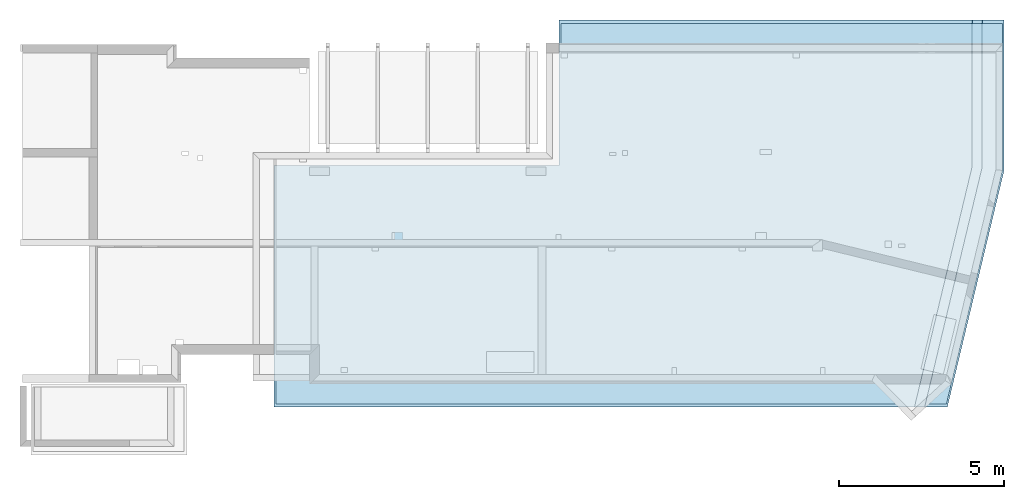
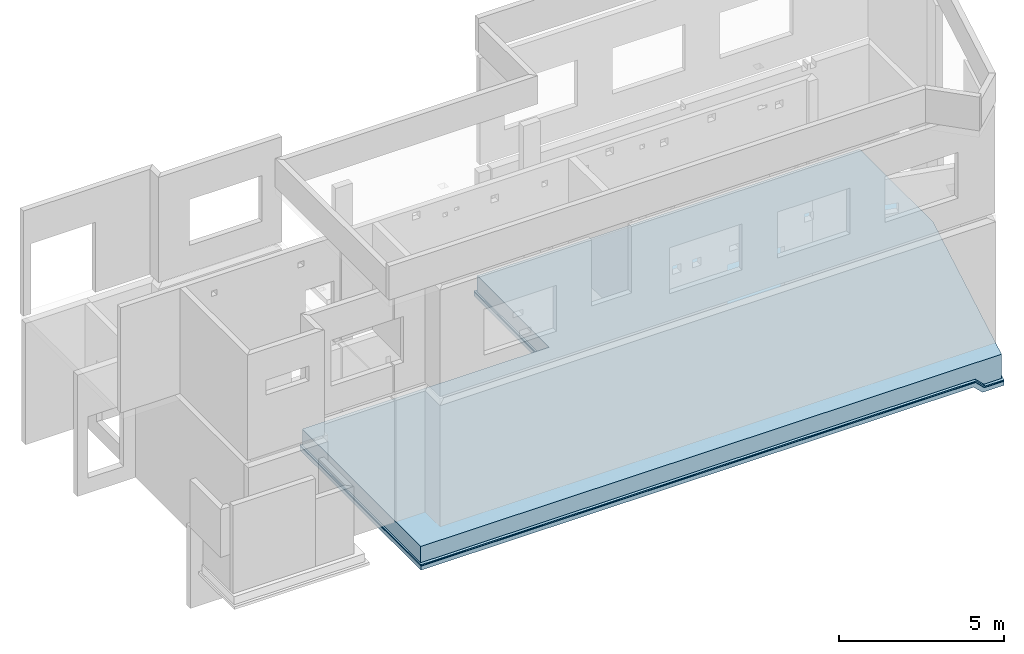
# One storey, part 7 of 7: 3 slabs.
"""IFC2X3 building model written with IfcOpenShell, lengths in millimetres."""

from ifc_helpers import new_model, entity, si_unit, converted_unit, derived_unit, money_unit, direction, frame, origin_with_axes, place, context, subcontext, project, spatial, faceted_brep, material, type_object, element, save


model = new_model("IFC2X3")

# Units and contexts
model_context = context("Model", 3, precision=1e-05, world=origin_with_axes(), true_north=direction((0.0, 1.0)))
body_context = subcontext(model_context, "Body", "Model", "MODEL_VIEW", scale=1.0)
ifc_project = project(units=[si_unit("LENGTHUNIT", "METRE", prefix="MILLI"), si_unit("AREAUNIT", "SQUARE_METRE"), si_unit("VOLUMEUNIT", "CUBIC_METRE"), si_unit("ABSORBEDDOSEUNIT", "GRAY"), si_unit("AMOUNTOFSUBSTANCEUNIT", "MOLE"), si_unit("DOSEEQUIVALENTUNIT", "SIEVERT"), si_unit("ELECTRICCAPACITANCEUNIT", "FARAD"), si_unit("ELECTRICCHARGEUNIT", "COULOMB"), si_unit("ELECTRICCONDUCTANCEUNIT", "SIEMENS"), si_unit("ELECTRICCURRENTUNIT", "AMPERE"), si_unit("ELECTRICRESISTANCEUNIT", "OHM"), si_unit("ELECTRICVOLTAGEUNIT", "VOLT"), si_unit("ENERGYUNIT", "JOULE"), si_unit("FORCEUNIT", "NEWTON"), si_unit("FREQUENCYUNIT", "HERTZ"), si_unit("ILLUMINANCEUNIT", "LUX"), si_unit("INDUCTANCEUNIT", "HENRY"), si_unit("LUMINOUSFLUXUNIT", "LUMEN"), si_unit("LUMINOUSINTENSITYUNIT", "CANDELA"), si_unit("MAGNETICFLUXDENSITYUNIT", "TESLA"), si_unit("MAGNETICFLUXUNIT", "WEBER"), si_unit("MASSUNIT", "GRAM"), converted_unit("PLANEANGLEUNIT", "degree", entity("IfcReal", 0.0174532925199433), si_unit("PLANEANGLEUNIT", "RADIAN"), dimensions=[0, 0, 0, 0, 0, 0, 0]), si_unit("POWERUNIT", "WATT"), si_unit("PRESSUREUNIT", "PASCAL"), si_unit("RADIOACTIVITYUNIT", "BECQUEREL"), si_unit("SOLIDANGLEUNIT", "STERADIAN"), si_unit("THERMODYNAMICTEMPERATUREUNIT", "KELVIN"), si_unit("TIMEUNIT", "SECOND"), derived_unit("ACCELERATIONUNIT", [(si_unit("LENGTHUNIT", "METRE", prefix="MILLI"), 1), (si_unit("TIMEUNIT", "SECOND"), -2)]), derived_unit("ANGULARVELOCITYUNIT", [(converted_unit("PLANEANGLEUNIT", "degree", entity("IfcReal", 0.0174532925199433), si_unit("PLANEANGLEUNIT", "RADIAN"), dimensions=[0, 0, 0, 0, 0, 0, 0]), 1), (si_unit("TIMEUNIT", "SECOND"), -1)]), derived_unit("CURVATUREUNIT", [(converted_unit("PLANEANGLEUNIT", "degree", entity("IfcReal", 0.0174532925199433), si_unit("PLANEANGLEUNIT", "RADIAN"), dimensions=[0, 0, 0, 0, 0, 0, 0]), 1), (si_unit("LENGTHUNIT", "METRE", prefix="MILLI"), -1)]), derived_unit("DYNAMICVISCOSITYUNIT", [(si_unit("PRESSUREUNIT", "PASCAL"), 1), (si_unit("TIMEUNIT", "SECOND"), 1)]), derived_unit("HEATFLUXDENSITYUNIT", [(si_unit("POWERUNIT", "WATT"), 1), (si_unit("LENGTHUNIT", "METRE", prefix="MILLI"), -2)]), derived_unit("HEATINGVALUEUNIT", [(si_unit("ENERGYUNIT", "JOULE"), 1), (si_unit("MASSUNIT", "GRAM"), -1)]), derived_unit("INTEGERCOUNTRATEUNIT", [(si_unit("TIMEUNIT", "SECOND"), -1)]), derived_unit("IONCONCENTRATIONUNIT", [(si_unit("MASSUNIT", "GRAM"), 1), (si_unit("VOLUMEUNIT", "CUBIC_METRE"), -1)]), derived_unit("ISOTHERMALMOISTURECAPACITYUNIT", [(si_unit("VOLUMEUNIT", "CUBIC_METRE"), 1), (si_unit("MASSUNIT", "GRAM"), -1)]), derived_unit("KINEMATICVISCOSITYUNIT", [(si_unit("AREAUNIT", "SQUARE_METRE"), 1), (si_unit("TIMEUNIT", "SECOND"), -1)]), derived_unit("LINEARFORCEUNIT", [(si_unit("FORCEUNIT", "NEWTON"), 1), (si_unit("LENGTHUNIT", "METRE", prefix="MILLI"), -1)]), derived_unit("LINEARMOMENTUNIT", [(si_unit("FORCEUNIT", "NEWTON"), 1), (si_unit("LENGTHUNIT", "METRE", prefix="MILLI"), -1)]), derived_unit("LINEARSTIFFNESSUNIT", [(si_unit("FORCEUNIT", "NEWTON"), 1), (si_unit("LENGTHUNIT", "METRE", prefix="MILLI"), -1)]), derived_unit("LINEARVELOCITYUNIT", [(si_unit("LENGTHUNIT", "METRE", prefix="MILLI"), 1), (si_unit("TIMEUNIT", "SECOND"), -1)]), derived_unit("LUMINOUSINTENSITYDISTRIBUTIONUNIT", [(si_unit("LUMINOUSINTENSITYUNIT", "CANDELA"), 1), (si_unit("LUMINOUSFLUXUNIT", "LUMEN"), -1)]), derived_unit("MASSDENSITYUNIT", [(si_unit("MASSUNIT", "GRAM"), 1), (si_unit("VOLUMEUNIT", "CUBIC_METRE"), -1)]), derived_unit("MASSFLOWRATEUNIT", [(si_unit("MASSUNIT", "GRAM"), 1), (si_unit("TIMEUNIT", "SECOND"), -1)]), derived_unit("MASSPERLENGTHUNIT", [(si_unit("MASSUNIT", "GRAM"), 1), (si_unit("LENGTHUNIT", "METRE", prefix="MILLI"), -1)]), derived_unit("MODULUSOFELASTICITYUNIT", [(si_unit("FORCEUNIT", "NEWTON"), 1), (si_unit("AREAUNIT", "SQUARE_METRE"), -1)]), derived_unit("MODULUSOFLINEARSUBGRADEREACTIONUNIT", [(si_unit("FORCEUNIT", "NEWTON"), 1), (si_unit("LENGTHUNIT", "METRE", prefix="MILLI"), -2)]), derived_unit("MODULUSOFROTATIONALSUBGRADEREACTIONUNIT", [(si_unit("FORCEUNIT", "NEWTON"), 1), (si_unit("LENGTHUNIT", "METRE", prefix="MILLI"), 1)]), derived_unit("MODULUSOFSUBGRADEREACTIONUNIT", [(si_unit("FORCEUNIT", "NEWTON"), 1), (si_unit("VOLUMEUNIT", "CUBIC_METRE"), -1)]), derived_unit("MOISTUREDIFFUSIVITYUNIT", [(si_unit("VOLUMEUNIT", "CUBIC_METRE"), 1), (si_unit("TIMEUNIT", "SECOND"), -1)]), derived_unit("MOLECULARWEIGHTUNIT", [(si_unit("MASSUNIT", "GRAM"), 1), (si_unit("AMOUNTOFSUBSTANCEUNIT", "MOLE"), -1)]), derived_unit("PLANARFORCEUNIT", [(si_unit("FORCEUNIT", "NEWTON"), 1), (si_unit("LENGTHUNIT", "METRE", prefix="MILLI"), -2)]), derived_unit("ROTATIONALFREQUENCYUNIT", [(si_unit("TIMEUNIT", "SECOND"), -1)]), derived_unit("ROTATIONALMASSUNIT", [(si_unit("MASSUNIT", "GRAM"), 1), (si_unit("LENGTHUNIT", "METRE", prefix="MILLI"), 2)]), derived_unit("ROTATIONALSTIFFNESSUNIT", [(si_unit("FORCEUNIT", "NEWTON"), 1), (si_unit("LENGTHUNIT", "METRE", prefix="MILLI"), 1), (converted_unit("PLANEANGLEUNIT", "degree", entity("IfcReal", 0.0174532925199433), si_unit("PLANEANGLEUNIT", "RADIAN"), dimensions=[0, 0, 0, 0, 0, 0, 0]), -1)]), derived_unit("SECTIONAREAINTEGRALUNIT", [(si_unit("LENGTHUNIT", "METRE", prefix="MILLI"), 5)]), derived_unit("SECTIONMODULUSUNIT", [(si_unit("LENGTHUNIT", "METRE", prefix="MILLI"), 3)]), derived_unit("SHEARMODULUSUNIT", [(si_unit("FORCEUNIT", "NEWTON"), 1), (si_unit("AREAUNIT", "SQUARE_METRE"), -1)]), derived_unit("SOUNDPOWERUNIT", [(si_unit("ENERGYUNIT", "JOULE"), 1), (si_unit("TIMEUNIT", "SECOND"), -1)]), derived_unit("SPECIFICHEATCAPACITYUNIT", [(si_unit("FORCEUNIT", "NEWTON"), 1), (si_unit("MASSUNIT", "GRAM"), -1), (si_unit("THERMODYNAMICTEMPERATUREUNIT", "KELVIN"), -1)]), derived_unit("TEMPERATUREGRADIENTUNIT", [(si_unit("THERMODYNAMICTEMPERATUREUNIT", "KELVIN"), 1), (si_unit("LENGTHUNIT", "METRE", prefix="MILLI"), -1)]), derived_unit("THERMALADMITTANCEUNIT", [(si_unit("POWERUNIT", "WATT"), 1), (si_unit("AREAUNIT", "SQUARE_METRE"), -1), (si_unit("THERMODYNAMICTEMPERATUREUNIT", "KELVIN"), -1)]), derived_unit("THERMALCONDUCTANCEUNIT", [(si_unit("POWERUNIT", "WATT"), 1), (si_unit("LENGTHUNIT", "METRE", prefix="MILLI"), -1), (si_unit("THERMODYNAMICTEMPERATUREUNIT", "KELVIN"), -1)]), derived_unit("THERMALEXPANSIONCOEFFICIENTUNIT", [(si_unit("THERMODYNAMICTEMPERATUREUNIT", "KELVIN"), -1)]), derived_unit("THERMALRESISTANCEUNIT", [(si_unit("AREAUNIT", "SQUARE_METRE"), 1), (si_unit("POWERUNIT", "WATT"), -1)]), derived_unit("THERMALTRANSMITTANCEUNIT", [(si_unit("POWERUNIT", "WATT"), 1), (si_unit("AREAUNIT", "SQUARE_METRE"), -1), (si_unit("THERMODYNAMICTEMPERATUREUNIT", "KELVIN"), -1)]), derived_unit("TORQUEUNIT", [(si_unit("FORCEUNIT", "NEWTON"), 1), (si_unit("LENGTHUNIT", "METRE", prefix="MILLI"), 1)]), derived_unit("VAPORPERMEABILITYUNIT", [(si_unit("MASSUNIT", "GRAM"), 1), (si_unit("TIMEUNIT", "SECOND"), -1)]), derived_unit("VOLUMETRICFLOWRATEUNIT", [(si_unit("VOLUMEUNIT", "CUBIC_METRE"), 1), (si_unit("TIMEUNIT", "SECOND"), -1)]), derived_unit("WARPINGCONSTANTUNIT", [(si_unit("LENGTHUNIT", "METRE", prefix="MILLI"), 6)]), derived_unit("WARPINGMOMENTUNIT", [(si_unit("FORCEUNIT", "NEWTON"), 1), (si_unit("LENGTHUNIT", "METRE", prefix="MILLI"), 2)]), money_unit("USD")], contexts=[model_context])

# Site, building, storey
site_placement = place(None, origin_with_axes())
site = spatial("IfcSite", under=ifc_project, at=site_placement, CompositionType="ELEMENT")
building_placement = place(site_placement, origin_with_axes())
building = spatial("IfcBuilding", under=site, at=building_placement, Name="1", CompositionType="ELEMENT")
storey_placement = place(building_placement, frame((0.0, 0.0, -4900.0), z_axis=(0.0, 0.0, 1.0), x_axis=(1.0, 0.0, 0.0)))
storey = spatial("IfcBuildingStorey", under=building, at=storey_placement, Name="-2", CompositionType="ELEMENT", Elevation=-4900.0)

# Slabs
ifc_material_1 = material()
slab_type_1 = type_object("IfcSlabType", PredefinedType="NOTDEFINED")
slab_1_placement = place(storey_placement, frame((16555.0, 10760.0, -600.0), z_axis=(0.0, 0.0, -1.0), x_axis=(1.0, 0.0, 0.0)))
element("IfcSlab", 1, at=slab_1_placement, inside=storey, type_object=slab_type_1, material=ifc_material_1, context=body_context, shape_type="Brep", body=[
    faceted_brep([(12844.0, 0.0, 300.0), (12844.0, 0.0, 340.0), (12544.0, 0.0, 40.0), (12560.0, 0.0, 40.0), (12560.0, 0.0, 0.0), (12860.0, 0.0, 300.0), (11119.02, 11760.0, 300.0), (10810.51, 11760.0, 0.0), (10810.51, 11760.0, 40.0), (10794.06, 11760.0, 40.0), (11102.56, 11760.0, 340.0), (11102.56, 11760.0, 300.0), (12504.0, 4456.99, 0.0), (10752.93, 11760.0, 0.0), (12560.0, 4463.61, 0.0), (12504.0, 0.0, 0.0), (0.0, 0.0, 0.0), (0.0, 4420.0, 0.0), (-8655.0, 4420.0, 0.0), (-8655.0, 11760.0, 0.0), (0.0, 0.0, 40.0), (0.0, 4420.0, 40.0), (-8655.0, 11760.0, 40.0), (-8655.0, 4420.0, 40.0), (12544.0, 4461.72, 40.0), (12860.0, 0.0, 340.0), (11119.02, 11760.0, 340.0), (12844.0, 4497.18, 340.0), (12860.0, 4499.07, 340.0), (12860.0, 4499.07, 300.0), (13510.0, 0.0, 340.0), (13510.0, 4575.91, 340.0), (11787.44, 11760.0, 340.0), (11787.44, 11760.0, 300.0), (13510.0, 0.0, 300.0), (13510.0, 4575.91, 300.0)], [[[0, 1, 2, 3, 4, 5]], [[6, 7, 8, 9, 10, 11]], [[12, 13, 7, 14, 4, 15]], [[15, 4, 3, 2]], [[9, 8, 7, 13]], [[12, 15, 16, 17, 18, 19, 13]], [[20, 21, 17, 16]], [[15, 2, 20, 16]], [[9, 13, 19, 22]], [[23, 22, 19, 18]], [[21, 23, 18, 17]], [[2, 24, 9, 22, 23, 21, 20]], [[0, 5, 25, 1]], [[6, 11, 10, 26]], [[2, 1, 27, 24]], [[24, 27, 10, 9]], [[10, 27, 1, 25, 28, 26]], [[14, 29, 5, 4]], [[14, 7, 6, 29]], [[28, 25, 30, 31, 32, 26]], [[6, 26, 32, 33]], [[25, 5, 34, 30]], [[29, 6, 33, 35, 34, 5]], [[31, 30, 34, 35]], [[32, 31, 35, 33]]]),
])
slab_2_placement = place(storey_placement, frame((7900.0, 6340.0, -650.0), z_axis=(0.0, 0.0, -1.0), x_axis=(1.0, 0.0, 0.0)))
element("IfcSlab", 2, at=slab_2_placement, inside=storey, type_object=slab_type_1, material=ifc_material_1, context=body_context, shape_type="Brep", body=[
    faceted_brep([(21432.73, -4420.0, 450.0), (21132.73, -4420.0, 150.0), (21194.85, -4420.0, 150.0), (21194.85, -4420.0, 0.0), (21194.86, -4420.0, 0.0), (21494.86, -4420.0, 300.0), (21432.73, -4420.0, 300.0), (19753.3, 7340.0, 300.0), (19444.8, 7340.0, 0.0), (19444.79, 7340.0, 0.0), (19444.79, 7340.0, 150.0), (19380.91, 7340.0, 150.0), (19689.41, 7340.0, 450.0), (19689.41, 7340.0, 300.0), (20982.73, -4420.0, 0.0), (20982.73, 16.15, 0.0), (19226.66, 7340.0, 0.0), (21194.85, 41.23, 0.0), (8655.0, -4420.0, 150.0), (8655.0, 0.0, 150.0), (8655.0, 0.0, 0.0), (8655.0, -4420.0, 0.0), (0.0, 0.0, 150.0), (0.0, 0.0, 0.0), (0.0, 7340.0, 0.0), (21132.73, 33.88, 150.0), (0.0, 7340.0, 150.0), (21494.86, -4420.0, 450.0), (19753.3, 7340.0, 450.0), (21432.73, 69.35, 450.0), (21194.86, 41.23, 0.0), (21494.86, 76.69, 450.0), (21494.86, 76.69, 300.0), (22165.0, -4420.0, 450.0), (22165.0, 155.91, 450.0), (20442.44, 7340.0, 450.0), (22165.0, -4420.0, 300.0), (20442.44, 7340.0, 300.0), (22165.0, 155.91, 300.0)], [[[0, 1, 2, 3, 4, 5, 6]], [[7, 8, 9, 10, 11, 12, 13]], [[14, 3, 2, 1]], [[15, 16, 9, 17, 3, 14]], [[11, 10, 9, 16]], [[18, 19, 20, 21]], [[14, 1, 18, 21]], [[19, 22, 23, 20]], [[15, 14, 21, 20, 23, 24, 16]], [[1, 25, 11, 26, 22, 19, 18]], [[22, 26, 24, 23]], [[11, 16, 24, 26]], [[0, 6, 5, 27]], [[7, 13, 12, 28]], [[1, 0, 29, 25]], [[3, 17, 9, 8, 30, 4]], [[25, 29, 12, 11]], [[12, 29, 0, 27, 31, 28]], [[30, 32, 5, 4]], [[30, 8, 7, 32]], [[31, 27, 33, 34, 35, 28]], [[27, 5, 36, 33]], [[7, 28, 35, 37]], [[34, 33, 36, 38]], [[32, 7, 37, 38, 36, 5]], [[35, 34, 38, 37]]]),
])
ifc_material_2 = material()
slab_type_2 = type_object("IfcSlabType", PredefinedType="NOTDEFINED")
slab_3_placement = place(storey_placement, frame((7950.0, 6290.0, 0.0), z_axis=(0.0, 0.0, -1.0), x_axis=(1.0, 0.0, 0.0)))
element("IfcSlab", 3, at=slab_3_placement, inside=storey, type_object=slab_type_2, material=ifc_material_2, context=body_context, shape_type="Brep", body=[
    faceted_brep([(21165.0, -6.39, 600.0), (19439.49, 7190.0, 600.0), (0.0, 7190.0, 600.0), (0.0, 0.0, 600.0), (8655.0, 0.0, 600.0), (8655.0, -4370.0, 600.0), (21165.0, -4370.0, 600.0), (0.0, 0.0, 0.0), (0.0, 7190.0, 0.0), (20365.0, 7190.0, 0.0), (22065.0, 100.0, 0.0), (22065.0, -4370.0, 0.0), (8655.0, -4370.0, 0.0), (8655.0, 0.0, 0.0), (22065.0, -4370.0, 600.0), (22065.0, 100.0, 600.0), (20365.0, 7190.0, 600.0), (21465.0, -4370.0, 900.0), (22065.0, -4370.0, 900.0), (22065.0, 100.0, 900.0), (20365.0, 7190.0, 900.0), (19747.99, 7190.0, 900.0), (21465.0, 29.07, 900.0)], [[[0, 1, 2, 3, 4, 5, 6]], [[7, 8, 9, 10, 11, 12, 13]], [[3, 2, 8, 7]], [[4, 3, 7, 13]], [[5, 4, 13, 12]], [[14, 6, 5, 12, 11]], [[15, 14, 11, 10]], [[16, 15, 10, 9]], [[2, 1, 16, 9, 8]], [[17, 6, 14, 18]], [[19, 18, 14, 15]], [[20, 19, 15, 16]], [[1, 21, 20, 16]], [[22, 17, 18, 19, 20, 21]], [[0, 22, 21, 1]], [[17, 22, 0, 6]]]),
])

save(model, "model.ifc")
